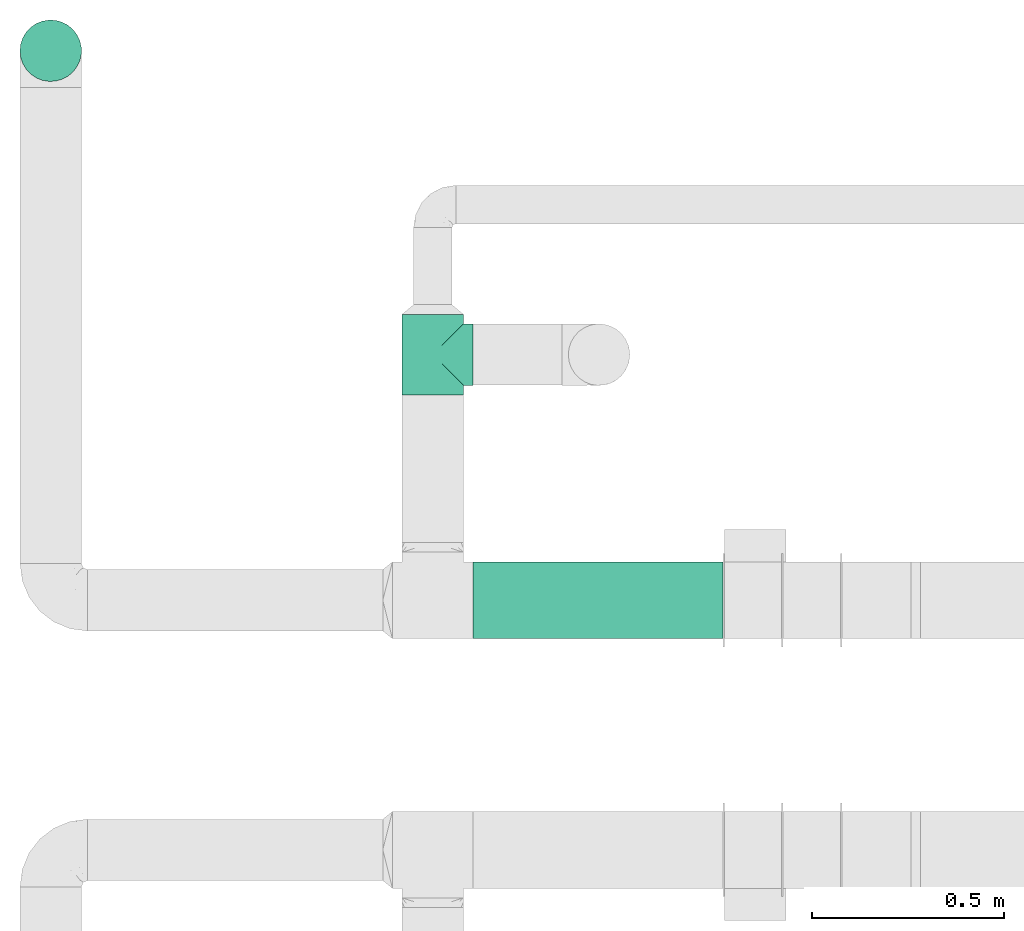
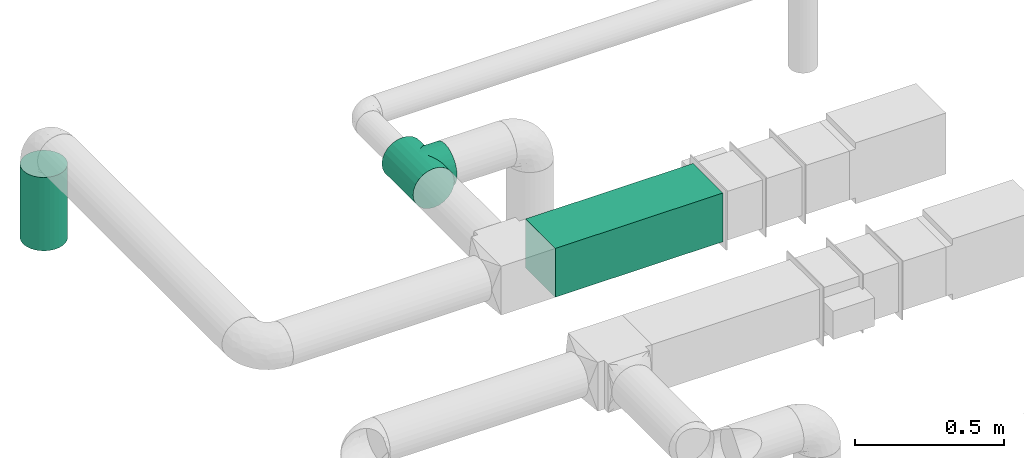
# One storey, part 9 of 12: 2 flow segments, 1 flow fitting.
"""IFC2X3 building model written with IfcOpenShell, lengths in millimetres."""

from ifc_helpers import new_model, entity, si_unit, converted_unit, derived_unit, direction, frame, frame_2d, origin, origin_2d_with_axis, place, context, subcontext, project, spatial, rectangle, circle, extrude, faceted_brep, source, transform, mapped, type_object, type_shapes, element, save


model = new_model("IFC2X3")

# Units and contexts
model_context = context("Model", 3, precision=0.01, world=origin(), true_north=direction((6.12303176911189e-17, 1.0)))
body_context = subcontext(model_context, "Body", "Model", "MODEL_VIEW")
ifc_project = project(units=[si_unit("LENGTHUNIT", "METRE", prefix="MILLI"), si_unit("AREAUNIT", "SQUARE_METRE"), si_unit("VOLUMEUNIT", "CUBIC_METRE"), converted_unit("PLANEANGLEUNIT", "DEGREE", entity("IfcRatioMeasure", 0.0174532925199433), si_unit("PLANEANGLEUNIT", "RADIAN"), dimensions=[0, 0, 0, 0, 0, 0, 0]), si_unit("MASSUNIT", "GRAM", prefix="KILO"), derived_unit("MASSDENSITYUNIT", [(si_unit("MASSUNIT", "GRAM", prefix="KILO"), 1), (si_unit("LENGTHUNIT", "METRE"), -3)]), si_unit("TIMEUNIT", "SECOND"), si_unit("FREQUENCYUNIT", "HERTZ"), si_unit("THERMODYNAMICTEMPERATUREUNIT", "DEGREE_CELSIUS"), derived_unit("THERMALTRANSMITTANCEUNIT", [(si_unit("MASSUNIT", "GRAM", prefix="KILO"), 1), (si_unit("THERMODYNAMICTEMPERATUREUNIT", "KELVIN"), -1), (si_unit("TIMEUNIT", "SECOND"), -3)]), derived_unit("VOLUMETRICFLOWRATEUNIT", [(si_unit("LENGTHUNIT", "METRE"), 3), (si_unit("TIMEUNIT", "SECOND"), -1)]), si_unit("ELECTRICCURRENTUNIT", "AMPERE"), si_unit("ELECTRICVOLTAGEUNIT", "VOLT"), si_unit("POWERUNIT", "WATT"), si_unit("FORCEUNIT", "NEWTON", prefix="KILO"), si_unit("ILLUMINANCEUNIT", "LUX"), si_unit("LUMINOUSFLUXUNIT", "LUMEN"), si_unit("LUMINOUSINTENSITYUNIT", "CANDELA"), derived_unit("USERDEFINED", [(si_unit("MASSUNIT", "GRAM", prefix="KILO"), -1), (si_unit("LENGTHUNIT", "METRE"), -2), (si_unit("TIMEUNIT", "SECOND"), 3), (si_unit("LUMINOUSFLUXUNIT", "LUMEN"), 1)]), derived_unit("LINEARVELOCITYUNIT", [(si_unit("LENGTHUNIT", "METRE"), 1), (si_unit("TIMEUNIT", "SECOND"), -1)]), si_unit("PRESSUREUNIT", "PASCAL"), derived_unit("USERDEFINED", [(si_unit("LENGTHUNIT", "METRE"), -2), (si_unit("MASSUNIT", "GRAM", prefix="KILO"), 1), (si_unit("TIMEUNIT", "SECOND"), -2)])], contexts=[model_context])

# Site, building, storey
site_placement = place(None, origin())
site = spatial("IfcSite", under=ifc_project, at=site_placement, CompositionType="ELEMENT")
building_placement = place(site_placement, origin())
building = spatial("IfcBuilding", under=site, at=building_placement, CompositionType="ELEMENT")
storey_placement = place(building_placement, frame((0.0, 0.0, 8000.0)))
storey = spatial("IfcBuildingStorey", under=building, at=storey_placement, Name="02 Level", CompositionType="ELEMENT", Elevation=8000.0)

# Flow segments
duct_segment_type_1 = type_object("IfcDuctSegmentType", Name="Round Duct:Air", PredefinedType="NOTDEFINED")
flow_segment_1_placement = place(storey_placement, frame((22110.1537099681, -67157.8348573759, 2603.07847999999)))
element("IfcFlowSegment", 1, at=flow_segment_1_placement, inside=storey, type_object=duct_segment_type_1, Name="Round Duct:Air", ObjectType="Round Duct:Air", context=body_context, shape_type="SweptSolid", body=[
    extrude(circle(Radius=79.9999999999999, at=origin_2d_with_axis()), frame((81.595272235915, 81.595272235915, 0.0), z_axis=(0.0, 0.0, 1.0), x_axis=(-1.0, 0.0, 0.0)), (0.0, 0.0, 1.0), 300.921520000008),
])
duct_segment_type_2 = type_object("IfcDuctSegmentType", Name="Rectangular Duct:Air", PredefinedType="NOTDEFINED")
flow_segment_2_placement = place(storey_placement, frame((23290.9900708518, -68606.4439409626, 2900.0)))
element("IfcFlowSegment", 2, at=flow_segment_2_placement, inside=storey, type_object=duct_segment_type_2, Name="Rectangular Duct:Air", ObjectType="Rectangular Duct:Air", context=body_context, shape_type="SweptSolid", body=[
    extrude(rectangle(XDim=650.000000000004, YDim=199.999999999998, at=frame_2d((-2.1600499167107e-12, -4.33431068813661e-12), x_axis=(1.0, 0.0))), frame((325.0, 100.0, 0.0), z_axis=(0.0, 0.0, 1.0), x_axis=(-1.0, 0.0, 0.0)), (0.0, 0.0, 1.0), 200.000000000002),
])

# Flow fitting
duct_fitting_type = type_object("IfcDuctFittingType", Name="Air_Tee 90_Circ", PredefinedType="NOTDEFINED")
shared_shape = source(origin(), body_context, "Body", "Brep", [
    faceted_brep([(-105.0, 0.0, -80.0), (-105.0, -20.705523608202, -77.2740661031254), (-105.0, -40.0, -69.2820323027551), (-105.0, -56.5685424949241, -56.5685424949238), (-105.0, -69.2820323027554, -40.0), (-105.0, -77.2740661031257, -20.7055236082016), (-105.0, -80.0, 0.0), (-105.0, -77.2740661031255, 20.7055236082026), (-105.0, -69.2820323027549, 40.0), (-105.0, -56.5685424949234, 56.5685424949245), (-105.0, -40.0, 69.2820323027556), (-105.0, -20.7055236082011, 77.2740661031257), (-105.0, 0.0, 80.0), (-105.0, 20.7055236082022, 77.2740661031253), (-105.0, 40.0, 69.2820323027547), (-105.0, 48.2842712474623, 62.925287398839), (-105.0, 56.5685424949241, 56.5685424949232), (-105.0, 62.9252873988397, 48.2842712474612), (-105.0, 69.2820323027552, 40.0), (-105.0, 73.2780492029403, 30.3527618041001), (-105.0, 75.2760576530329, 25.5291427061505), (-105.0, 77.2740661031254, 20.7055236082009), (-105.0, 77.955549577344, 15.5291427061506), (-105.0, 78.6370330515626, 10.3527618041003), (-105.0, 79.3185165257812, 5.17638090205002), (-105.0, 80.0, 0.0), (-105.0, 79.3185165257811, -5.17638090205062), (-105.0, 78.6370330515624, -10.3527618041011), (-105.0, 77.9555495773438, -15.5291427061515), (-105.0, 77.2740661031251, -20.7055236082019), (-105.0, 75.2760576530325, -25.5291427061515), (-105.0, 73.2780492029399, -30.352761804101), (-105.0, 69.2820323027547, -40.0), (-105.0, 62.9252873988391, -48.2842712474621), (-105.0, 56.5685424949234, -56.5685424949239), (-105.0, 48.2842712474615, -62.9252873988396), (-105.0, 40.0, -69.2820323027552), (-105.0, 20.7055236082013, -77.2740661031255), (105.0, -40.0, -69.2820323027551), (105.0, -20.7055236082014, -77.2740661031254), (105.0, 0.0, -80.0), (105.0, 20.7055236082019, -77.2740661031255), (105.0, 40.0, -69.2820323027552), (105.0, 48.2842712474622, -62.9252873988395), (105.0, 56.5685424949241, -56.5685424949239), (105.0, 62.9252873988397, -48.2842712474621), (105.0, 69.2820323027554, -40.0), (105.0, 73.2780492029406, -30.352761804101), (105.0, 75.2760576530332, -25.5291427061515), (105.0, 77.2740661031258, -20.7055236082019), (105.0, 77.9555495773445, -15.5291427061515), (105.0, 78.6370330515631, -10.3527618041011), (105.0, 79.3185165257817, -5.17638090205064), (105.0, 80.0, 0.0), (105.0, 79.3185165257818, 5.17638090205008), (105.0, 78.6370330515632, 10.3527618041003), (105.0, 77.9555495773447, 15.5291427061506), (105.0, 77.2740661031261, 20.7055236082009), (105.0, 75.2760576530335, 25.5291427061505), (105.0, 73.278049202941, 30.3527618041001), (105.0, 69.2820323027559, 40.0), (105.0, 62.9252873988403, 48.2842712474612), (105.0, 56.5685424949248, 56.5685424949232), (105.0, 48.284271247463, 62.9252873988389), (105.0, 40.0, 69.2820323027547), (105.0, 20.7055236082029, 77.2740661031253), (105.0, 0.0, 80.0), (105.0, -20.7055236082004, 77.2740661031257), (105.0, -40.0, 69.2820323027556), (105.0, -56.5685424949228, 56.5685424949245), (105.0, -69.2820323027542, 40.0), (105.0, -77.2740661031248, 20.7055236082026), (105.0, -80.0, 0.0), (105.0, -77.2740661031251, -20.7055236082016), (105.0, -69.2820323027547, -40.0), (105.0, -56.5685424949235, -56.5685424949238), (78.227899039511, 78.2278990395113, 16.7450234954769), (-78.227899039511, 78.2278990395108, 16.7450234954769), (79.1139495197555, 79.1139495197558, 8.37251174773832), (76.9834675239615, 76.9834675239618, 20.5993372484815), (75.7390360084121, 75.7390360084124, 24.4536510014862), (73.2501729773131, 73.2501729773134, 32.1622785074954), (61.2529055661489, 61.2529055661492, 50.9613067090927), (56.6842556369154, 56.6842556369157, 56.452592171563), (46.3970120620784, 46.3970120620786, 65.1714452172986), (-73.2501729773132, 73.250172977313, 32.1622785074954), (65.8215554953824, 65.8215554953827, 45.4700212466224), (-46.3970120620785, 46.3970120620784, 65.1714452172985), (-69.5358642363478, 69.5358642363476, 38.8161498770589), (-65.8215554953824, 65.8215554953822, 45.4700212466225), (69.5358642363477, 69.5358642363481, 38.8161498770589), (-75.7390360084121, 75.7390360084119, 24.4536510014861), (-76.9834675239616, 76.9834675239614, 20.5993372484815), (-78.6709242796333, 78.6709242796331, 12.5587676216076), (-79.1139495197555, 79.1139495197553, 8.37251174773832), (-79.5569747598778, 79.5569747598776, 4.18625587386907), (-80.0, 80.0, 0.0), (80.0, 80.0, 0.0), (79.5569747598777, 79.5569747598781, 4.18625587386903), (78.6709242796332, 78.6709242796336, 12.5587676216076), (-56.6842556369155, 56.6842556369154, 56.452592171563), (-61.252905566149, 61.2529055661488, 50.9613067090927), (-35.3477594379945, 35.3477594379945, 71.7672341860383), (35.3477594379944, 35.3477594379946, 71.7672341860384), (11.9716475671883, 11.9716475671884, 79.0991760673083), (23.8067106814643, 23.8067106814644, 76.3756540170299), (0.0, 0.0, 80.0), (-11.9716475671884, 11.9716475671884, 79.0991760673083), (-23.8067106814644, 23.8067106814643, 76.3756540170299), (-79.1139495197555, 79.1139495197553, -8.3725117477387), (-78.6709242796332, 78.670924279633, -12.5587676216079), (-79.5569747598777, 79.5569747598776, -4.18625587386946), (79.5569747598777, 79.5569747598781, -4.18625587386948), (75.7390360084119, 75.7390360084122, -24.4536510014866), (0.0, 0.0, -80.0), (11.971647567188, 11.9716475671882, -79.0991760673083), (-75.739036008412, 75.7390360084118, -24.4536510014865), (-11.9716475671881, 11.9716475671881, -79.0991760673083), (23.806710681464, 23.8067106814643, -76.3756540170299), (69.5358642363476, 69.5358642363478, -38.8161498770593), (73.250172977313, 73.2501729773133, -32.1622785074958), (65.8215554953821, 65.8215554953824, -45.4700212466228), (78.6709242796332, 78.6709242796335, -12.558767621608), (79.1139495197555, 79.1139495197558, -8.37251174773877), (61.2529055661487, 61.252905566149, -50.961306709093), (-69.5358642363476, 69.5358642363474, -38.8161498770592), (-65.8215554953822, 65.8215554953821, -45.4700212466227), (-73.250172977313, 73.2501729773128, -32.1622785074957), (76.9834675239614, 76.9834675239618, -20.5993372484819), (78.2278990395109, 78.2278990395112, -16.7450234954773), (-35.3477594379943, 35.3477594379942, -71.7672341860385), (-23.8067106814641, 23.8067106814641, -76.37565401703), (35.3477594379942, 35.3477594379944, -71.7672341860385), (56.6842556369152, 56.6842556369155, -56.4525921715632), (-46.3970120620782, 46.3970120620781, -65.1714452172987), (-56.6842556369153, 56.6842556369152, -56.4525921715632), (46.3970120620782, 46.3970120620784, -65.1714452172987), (-76.9834675239615, 76.9834675239613, -20.5993372484819), (-78.2278990395109, 78.2278990395108, -16.7450234954772), (-61.2529055661488, 61.2529055661486, -50.9613067090929), (40.0, 105.0, -69.2820323027551), (20.7055236082017, 105.0, -77.2740661031254), (0.0, 105.0, -80.0), (-20.7055236082016, 105.0, -77.2740661031255), (-40.0, 105.0, -69.2820323027552), (-56.5685424949237, 105.0, -56.5685424949239), (-69.282032302755, 105.0, -40.0), (-73.2780492029402, 105.0, -30.352761804101), (-77.2740661031254, 105.0, -20.7055236082019), (-78.6370330515627, 105.0, -10.352761804101), (-80.0, 105.0, 0.0), (-78.6370330515629, 105.0, 10.3527618041003), (-77.2740661031257, 105.0, 20.7055236082009), (-73.2780492029406, 105.0, 30.3527618041001), (-69.2820323027555, 105.0, 40.0), (-56.5685424949244, 105.0, 56.5685424949232), (-40.0, 105.0, 69.2820323027547), (-20.7055236082025, 105.0, 77.2740661031253), (0.0, 105.0, 80.0), (20.7055236082008, 105.0, 77.2740661031257), (40.0, 105.0, 69.2820323027556), (56.5685424949231, 105.0, 56.5685424949245), (69.2820323027546, 105.0, 40.0), (73.2780492029399, 105.0, 30.3527618041017), (77.2740661031252, 105.0, 20.7055236082026), (78.6370330515626, 105.0, 10.3527618041018), (80.0, 105.0, 0.0), (78.6370330515627, 105.0, -10.3527618041008), (77.2740661031254, 105.0, -20.7055236082016), (73.2780492029403, 105.0, -30.3527618041008), (69.2820323027551, 105.0, -40.0), (56.5685424949238, 105.0, -56.5685424949238)], [[[0, 1, 2, 3, 4, 5, 6, 7, 8, 9, 10, 11, 12, 13, 14, 15, 16, 17, 18, 19, 20, 21, 22, 23, 24, 25, 26, 27, 28, 29, 30, 31, 32, 33, 34, 35, 36, 37]], [[38, 39, 40, 41, 42, 43, 44, 45, 46, 47, 48, 49, 50, 51, 52, 53, 54, 55, 56, 57, 58, 59, 60, 61, 62, 63, 64, 65, 66, 67, 68, 69, 70, 71, 72, 73, 74, 75]], [[76, 57, 56]], [[22, 21, 77]], [[78, 55, 54]], [[57, 76, 79, 80]], [[81, 60, 59]], [[82, 83, 62]], [[64, 63, 84]], [[19, 18, 85]], [[82, 61, 86]], [[63, 62, 83]], [[15, 14, 87]], [[88, 85, 18, 89]], [[81, 90, 86, 60]], [[91, 92, 77, 21]], [[91, 19, 85]], [[20, 19, 91, 21]], [[22, 77, 93]], [[94, 95, 24]], [[96, 25, 95]], [[97, 98, 53]], [[58, 57, 80, 59]], [[76, 56, 99]], [[100, 101, 16]], [[100, 15, 87]], [[101, 17, 16]], [[18, 17, 89]], [[16, 15, 100]], [[78, 99, 55]], [[61, 82, 62]], [[102, 87, 14]], [[93, 23, 22]], [[101, 89, 17]], [[103, 64, 84]], [[104, 66, 65]], [[54, 53, 98]], [[65, 103, 105]], [[65, 105, 104]], [[61, 60, 86]], [[106, 66, 104]], [[12, 106, 107]], [[64, 103, 65]], [[70, 69, 9, 8]], [[71, 70, 8, 7]], [[68, 67, 11, 10]], [[69, 68, 10, 9]], [[66, 106, 12, 11, 67]], [[72, 71, 7, 6]], [[81, 59, 80]], [[13, 107, 108]], [[102, 13, 108]], [[12, 107, 13]], [[55, 99, 56]], [[14, 13, 102]], [[84, 63, 83]], [[24, 95, 25]], [[24, 23, 94]], [[98, 78, 54]], [[93, 94, 23]], [[109, 110, 27]], [[96, 111, 25]], [[97, 53, 112]], [[48, 47, 113, 49]], [[74, 4, 3, 75]], [[74, 73, 5, 4]], [[38, 75, 3, 2]], [[73, 72, 6, 5]], [[40, 39, 1, 0, 114]], [[111, 109, 26]], [[41, 40, 115]], [[30, 29, 116, 31]], [[40, 114, 115]], [[117, 114, 0]], [[41, 115, 118]], [[119, 120, 46, 121]], [[122, 51, 50]], [[1, 39, 38, 2]], [[122, 123, 51]], [[124, 121, 45]], [[52, 51, 123]], [[125, 126, 32, 127]], [[113, 128, 129, 49]], [[37, 130, 131]], [[37, 131, 117]], [[37, 117, 0]], [[37, 36, 130]], [[132, 41, 118]], [[43, 133, 44]], [[134, 35, 135]], [[133, 43, 136]], [[124, 45, 44]], [[127, 31, 116]], [[121, 46, 45]], [[132, 136, 42]], [[52, 123, 112]], [[50, 49, 129]], [[113, 47, 120]], [[129, 122, 50]], [[137, 116, 29, 138]], [[52, 112, 53]], [[33, 139, 34]], [[133, 124, 44]], [[43, 42, 136]], [[35, 34, 135]], [[130, 36, 134]], [[36, 35, 134]], [[33, 126, 139]], [[135, 34, 139]], [[33, 32, 126]], [[47, 46, 120]], [[26, 25, 111]], [[109, 27, 26]], [[32, 31, 127]], [[28, 138, 29]], [[27, 110, 28]], [[138, 28, 110]], [[41, 132, 42]], [[140, 141, 142, 143, 144, 145, 146, 147, 148, 149, 150, 151, 152, 153, 154, 155, 156, 157, 158, 159, 160, 161, 162, 163, 164, 165, 166, 167, 168, 169, 170, 171]], [[77, 152, 151]], [[165, 164, 76]], [[94, 151, 150]], [[152, 77, 92, 91, 85]], [[87, 156, 155]], [[155, 154, 89]], [[154, 153, 152, 85]], [[157, 156, 102]], [[165, 78, 166]], [[154, 85, 88, 89]], [[155, 100, 87]], [[155, 89, 101, 100]], [[157, 102, 108]], [[107, 106, 158]], [[107, 157, 108]], [[102, 156, 87]], [[158, 157, 107]], [[159, 103, 160]], [[158, 104, 159]], [[161, 160, 84]], [[166, 78, 98, 97]], [[86, 162, 161]], [[163, 162, 81, 164]], [[165, 76, 99, 78]], [[160, 103, 84]], [[159, 104, 105]], [[159, 105, 103]], [[164, 81, 80, 79, 76]], [[150, 96, 95, 94]], [[161, 83, 82, 86]], [[151, 94, 93, 77]], [[162, 86, 90, 81]], [[83, 161, 84]], [[106, 104, 158]], [[129, 168, 167]], [[169, 168, 120, 170]], [[123, 167, 166]], [[168, 129, 128, 113, 120]], [[147, 146, 127, 148]], [[149, 109, 150]], [[171, 170, 121]], [[149, 148, 138]], [[136, 140, 171]], [[141, 140, 132]], [[170, 120, 119, 121]], [[171, 133, 136]], [[171, 121, 124, 133]], [[141, 132, 118]], [[115, 114, 142]], [[115, 141, 118]], [[132, 140, 136]], [[167, 123, 122, 129]], [[142, 141, 115]], [[143, 130, 144]], [[142, 117, 143]], [[145, 144, 134]], [[150, 109, 111, 96]], [[126, 146, 145]], [[149, 138, 110, 109]], [[144, 130, 134]], [[143, 117, 131]], [[143, 131, 130]], [[166, 97, 112, 123]], [[148, 127, 116, 137, 138]], [[145, 135, 139, 126]], [[146, 126, 125, 127]], [[135, 145, 134]], [[114, 117, 142]]]),
])
type_shapes(duct_fitting_type, [shared_shape])
flow_fitting_placement = place(storey_placement, frame((23185.9900708518, -67867.2449387878, 3000.0), z_axis=(0.0, 0.0, 1.0), x_axis=(0.0, -1.0, 0.0)))
element("IfcFlowFitting", 3, at=flow_fitting_placement, inside=storey, type_object=duct_fitting_type, Name="tee_90_001:Air_Tee 90_Circ", ObjectType="tee_90_001:Air_Tee 90_Circ", context=body_context, shape_type="MappedRepresentation", body=[
    mapped(shared_shape, transform((0.0, 0.0, 0.0), scale=1.0)),
])

save(model, "model.ifc")
